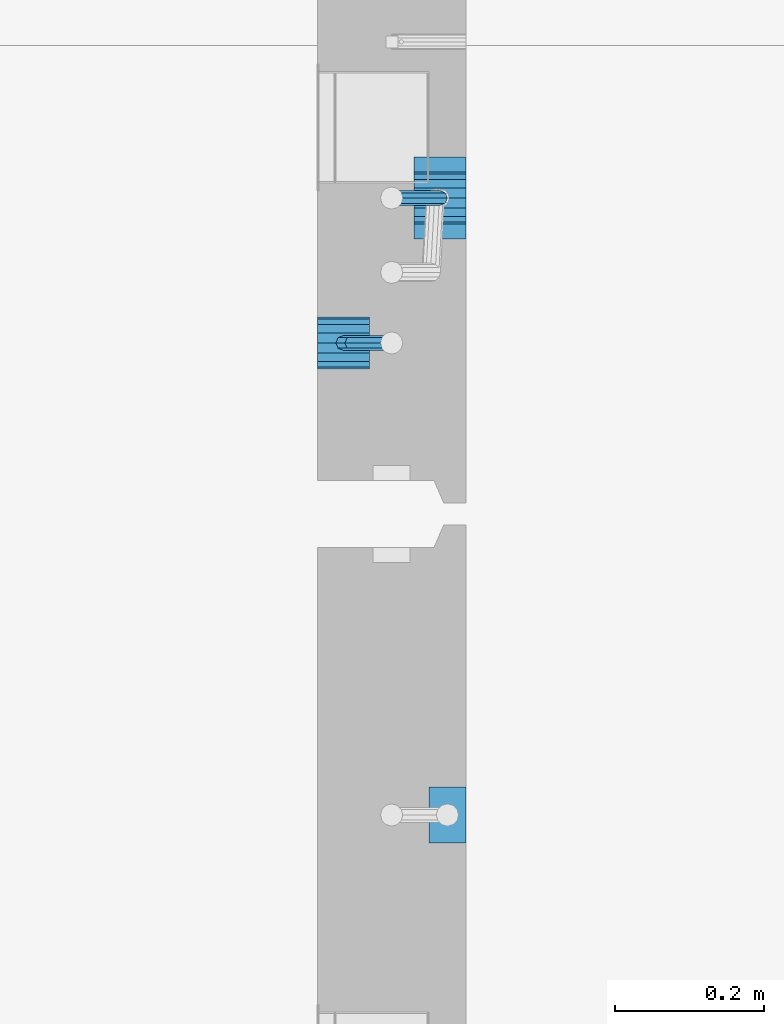
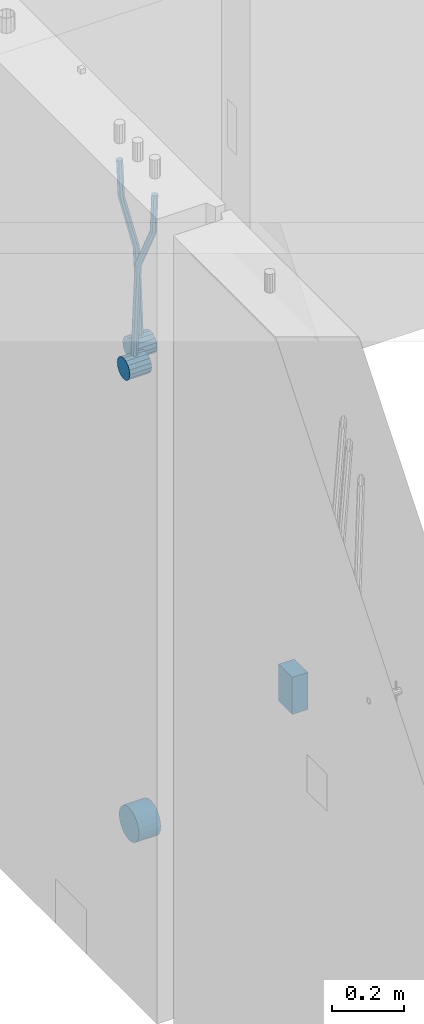
# One storey, part 141 of 334: 6 beams, 2 elements without a shape of their own.
"""IFC2X3 building model written with IfcOpenShell, lengths in millimetres."""

from ifc_helpers import new_model, si_unit, frame, origin_with_axes, place, context, subcontext, project, spatial, faceted_brep, material, type_object, element, aggregate, save


model = new_model("IFC2X3")

# Units and contexts
model_context = context("Model", 3, precision=1e-05, world=origin_with_axes())
body_context = subcontext(model_context, "Body", "Model", "MODEL_VIEW")
ifc_project = project(units=[si_unit("LENGTHUNIT", "METRE", prefix="MILLI"), si_unit("AREAUNIT", "SQUARE_METRE"), si_unit("VOLUMEUNIT", "CUBIC_METRE"), si_unit("MASSUNIT", "GRAM", prefix="KILO"), si_unit("TIMEUNIT", "SECOND"), si_unit("PLANEANGLEUNIT", "RADIAN"), si_unit("SOLIDANGLEUNIT", "STERADIAN"), si_unit("THERMODYNAMICTEMPERATUREUNIT", "DEGREE_CELSIUS"), si_unit("LUMINOUSINTENSITYUNIT", "LUMEN")], contexts=[model_context])

# Site, building, storey
site_placement = place(None, origin_with_axes())
site = spatial("IfcSite", under=ifc_project, at=site_placement, CompositionType="ELEMENT")
building_placement = place(site_placement, origin_with_axes())
building = spatial("IfcBuilding", under=site, at=building_placement, CompositionType="ELEMENT")
storey_placement = place(building_placement, origin_with_axes())
storey = spatial("IfcBuildingStorey", under=building, at=storey_placement, Name="3", CompositionType="ELEMENT", Elevation=0.0)

# Assembly, beams
assembly_1_placement = place(storey_placement, origin_with_axes())
assembly_1 = element("IfcElementAssembly", 1, at=assembly_1_placement, inside=storey, AssemblyPlace="NOTDEFINED", PredefinedType="REINFORCEMENT_UNIT")
ifc_material = material()
beam_type_1 = type_object("IfcBeamType", Name="D20", PredefinedType="NOTDEFINED")
beam_1_placement = place(assembly_1_placement, frame((21875.0000022791, 12925.0000000039, 89795.0), z_axis=(-0.999642804636942, -0.000205726999925762, -0.0267249099902983), x_axis=(-0.0267249099948371, 4.30000201934385e-08, 0.999642825806181)))
beam_1 = element("IfcBeam", 2, at=beam_1_placement, type_object=beam_type_1, material=ifc_material, Name="JM20", ObjectType="D20", context=body_context, shape_type="Brep", body=[
    faceted_brep([(0.0, -10.0, 0.0), (-4.19531716033816e-08, -7.07106781186667, -7.07106781187031), (60.4266690400545, -7.0710677960451, -7.07106780570757), (60.4266690441291, -9.99999998418934, 6.15546014159918e-09), (0.0, 0.0, -10.0), (60.426669036824, 1.58106558956206e-08, -9.99999999384454), (4.196772351861e-08, 7.07106781186303, -7.07106781186667), (60.4266690363438, 7.07106782768096, -7.07106780570757), (0.0, 10.0, 0.0), (60.4266690388904, 10.0000000158179, 6.15182216279209e-09), (4.196772351861e-08, 7.07106781185939, 7.07106781185939), (60.4266690429649, 7.07106782768096, 7.07106781802577), (0.0, 0.0, 10.0), (60.4266690461809, 1.58179318532348e-08, 10.0000000061555), (-4.19531716033816e-08, -7.07106781187031, 7.07106781185939), (60.4266690466611, -7.07106779605238, 7.07106781802213), (61.0378400410118, -7.07106779588503, -7.07106780564936), (60.991799419251, -9.99999998403655, 6.21366780251265e-09), (61.0569027789461, 1.5985278878361e-08, -9.99999999378269), (61.0378209396877, 7.07106782784831, -7.07106780564936), (60.9917724058905, 10.0000000159635, 6.21366780251265e-09), (60.9457317841297, 7.07106782781193, 7.0710678180767), (60.9266690461809, 1.59488990902901e-08, 10.0000000062028), (60.9457508854539, -7.07106779591413, 7.0710678180767), (61.6489592143771, -7.07106614513759, -7.06310863441468), (61.5568818710308, -9.9999984576425, 0.00735959856683621), (61.6870830769039, 1.71821739058942e-06, -9.99179257185824), (61.6489210170112, 7.07106947854481, -7.06310888312146), (61.556827851804, 10.0000015422847, 0.00735924683976918), (61.4647505084577, 7.07106922979438, 7.07782747982128), (61.4266266459163, 1.36643211590126e-06, 10.0065114172685), (61.464788705809, -7.07106639389531, 7.07782772852806), (176.543135720174, -7.07075579406956, -5.56673531796696), (176.451058376813, -9.99968810657447, 1.50373291501455), (176.581259582701, 0.000312069292704109, -8.49541925541052), (176.543097522794, 7.07137982961285, -5.56673556667374), (176.451004357587, 10.00031189336, 1.50373256329476), (176.35892701424, 7.07137958085514, 8.57420079627263), (176.320803151699, 0.000311717507429421, 11.5028847337162), (176.358965211621, -7.07075604281999, 8.57420104497578), (177.098753836006, -7.07075429323595, -5.55949898843028), (176.98362511232, -9.99968666800123, 1.510669025065), (177.146421932586, 0.000313595905026887, -8.48805862247536), (177.098706077581, 7.07138133041735, -5.55949936166144), (176.983557571715, 10.0003133318824, 1.51066849724157), (176.868428848029, 7.07138095712435, 8.58083651073321), (176.820760751449, 0.000313067976094317, 11.5093961447819), (176.868476606425, -7.07075466652896, 8.58083688396073), (177.654312950661, -7.07075204110879, -5.54863964998367), (177.516135294456, -9.99968450931192, 1.52107783331303), (177.711524267797, 0.000315886711177882, -8.47701274570863), (177.654255632195, 7.07138358250813, -5.54864021007961), (177.516054233929, 10.0003154905207, 1.5210770412159), (177.377876577739, 7.0713830223176, 8.59079452451624), (177.320665260588, 0.000315094497636892, 11.5191676202448), (177.377933896176, -7.07075260129932, 8.59079508461218), (298.592214475648, -7.07025824167067, -3.18470470795364), (298.454036904819, -9.99919071054683, 3.88501277673276), (298.649425586758, 0.000809686429420253, -6.11307780703646), (298.592156745173, 7.07187738194261, -3.18470527475802), (298.453955261604, 10.0008092892858, 3.88501197515143), (298.315777690761, 7.07187682041331, 10.9547294598378), (298.258566579665, 0.000808892309578368, 13.883102558917), (298.31583542125, -7.07025880319998, 10.9547300266422), (300.829882012156, -7.07024910539985, -3.14096572775816), (299.972022738802, -9.99918451269514, 3.91468436611831), (301.18507173346, 0.000820039333120803, -6.0635143331092), (300.829526581147, 7.07188651699835, -3.14097211362241), (299.971520083447, 10.0008154854204, 3.91467533514515), (299.113660810108, 7.07188007812692, 10.9703254290253), (298.758471088819, 0.000810933392131119, 13.8928740343799), (299.114016241103, -7.07025554427128, 10.9703318148859), (303.012825988379, -7.0701468967527, -2.64717965084128), (301.452885279024, -9.99911517653163, 4.24965828764471), (303.65870706641, 0.000935858577577164, -5.50397331873319), (303.012180137302, 7.07198871204673, -2.64725173027909), (301.451971907663, 10.0008848023517, 4.24955635192964), (299.892031198324, 7.07191652257279, 11.1463942904193), (299.246150120278, 0.000833767242511385, 14.0031879583075), (299.892677049385, -7.07021908622846, 11.1464663698534), (490.480206458145, -7.06136939830685, 39.7582981627347), (488.920265748791, -9.9903376780876, 46.6551361012243), (491.126087536177, 0.00971335702342913, 36.9015044948464), (490.479560607055, 7.0807662104944, 39.7582260832969), (488.91935237743, 10.0096623007976, 46.6550341655056), (487.359411668076, 7.08069402101864, 53.5518721039953), (486.713530590045, 0.00961126568654436, 56.4086657718872), (487.360057519167, -7.06144158778261, 53.5519441834331), (491.222094319732, -7.06133466202664, 39.9261146072568), (490.367102775039, -9.9902699350514, 46.9824133868096), (491.613766567636, 0.0097361908719904, 37.0118184187741), (491.312683227967, 7.08080521851844, 39.9466800038063), (490.495214837676, 10.0097360849959, 47.0114972495248), (489.640223292983, 7.08080081197113, 54.0677960290814), (489.248551045079, 0.00972995907250152, 56.9820922175604), (489.549634384748, -7.06133906857212, 54.0472306325282), (491.98259360576, -7.07125184727738, 39.9362361015701), (491.850235984879, -10.009610527557, 47.0021524248696), (492.113679795017, 0.00321714190249622, 37.0184717700395), (492.166706040836, 7.06966845271199, 39.958046203883), (492.110610287549, 9.988670745126, 47.0329965673554), (491.978252666668, 7.05031206484455, 54.0989128906476), (491.847166477397, -0.0241569243353297, 57.0166772221819), (491.794140231592, -7.09060823514483, 54.077102788342), (512.839684553823, -7.34323584322192, 40.2138233804726), (512.707326932941, -10.2815945235034, 47.2797397037684), (512.970770743079, -0.268766854042042, 37.296059048942), (513.023796988884, 6.79768445676746, 40.2356334827819), (512.967701235597, 9.71668674918146, 47.3105838462543), (512.83534361473, 6.77832806890183, 54.3765001695538), (512.704257425459, -0.296140920279868, 57.2942645010808), (512.651231179654, -7.36259223108937, 54.3546900672372), (513.475042066755, -7.35152113457298, 40.2222793613946), (513.367413171509, -10.2902022863618, 47.2885247996019), (513.548971693657, -0.276306803183616, 37.3037543324754), (513.545895079456, 6.79087610917486, 40.2425820926655), (513.467614462992, 9.71016770021379, 47.3172371975234), (513.359985567746, 6.77148654842495, 54.3834826357306), (513.286055940844, -0.303727782968053, 57.3020076646499), (513.289132555044, -7.37091069532653, 54.3631799044524), (514.110453382629, -7.34964673829199, 40.2305416874733), (514.027555144421, -10.2882337755309, 47.2971163788461), (514.127221878356, -0.274611275939606, 37.3112548247955), (514.06803787424, 6.7924127919523, 40.249334442502), (513.967570557215, 9.71165861202826, 47.3236933478729), (513.884672319007, 6.77307157479117, 54.3902680392421), (513.867903823266, -0.301963887563034, 57.3095549019235), (513.927087827382, -7.36898795545494, 54.3714752842207), (614.131240716772, -7.05138387012084, 41.5279197320488), (614.048342478563, -9.98997090735793, 48.5944944234179), (614.148009212484, 0.0236515922315448, 38.6086328693636), (614.088825208368, 7.09067566012527, 41.5467124870702), (613.988357891343, 10.0099214802012, 48.6210713924484), (613.905459653135, 7.07133444296232, 55.6876460838175), (613.888691157408, -0.00370101939006418, 58.606932946499), (613.947875161524, -7.07072508728379, 55.6688533287888)], [[[0, 1, 2, 3]], [[1, 4, 5, 2]], [[4, 6, 7, 5]], [[6, 8, 9, 7]], [[8, 10, 11, 9]], [[10, 12, 13, 11]], [[12, 14, 15, 13]], [[14, 0, 3, 15]], [[14, 12, 10, 8, 6, 4, 1, 0]], [[3, 2, 16, 17]], [[2, 5, 18, 16]], [[5, 7, 19, 18]], [[7, 9, 20, 19]], [[9, 11, 21, 20]], [[11, 13, 22, 21]], [[13, 15, 23, 22]], [[15, 3, 17, 23]], [[17, 16, 24, 25]], [[16, 18, 26, 24]], [[18, 19, 27, 26]], [[19, 20, 28, 27]], [[20, 21, 29, 28]], [[21, 22, 30, 29]], [[22, 23, 31, 30]], [[23, 17, 25, 31]], [[25, 24, 32, 33]], [[24, 26, 34, 32]], [[26, 27, 35, 34]], [[27, 28, 36, 35]], [[28, 29, 37, 36]], [[29, 30, 38, 37]], [[30, 31, 39, 38]], [[31, 25, 33, 39]], [[33, 32, 40, 41]], [[32, 34, 42, 40]], [[34, 35, 43, 42]], [[35, 36, 44, 43]], [[36, 37, 45, 44]], [[37, 38, 46, 45]], [[38, 39, 47, 46]], [[39, 33, 41, 47]], [[41, 40, 48, 49]], [[40, 42, 50, 48]], [[42, 43, 51, 50]], [[43, 44, 52, 51]], [[44, 45, 53, 52]], [[45, 46, 54, 53]], [[46, 47, 55, 54]], [[47, 41, 49, 55]], [[49, 48, 56, 57]], [[48, 50, 58, 56]], [[50, 51, 59, 58]], [[51, 52, 60, 59]], [[52, 53, 61, 60]], [[53, 54, 62, 61]], [[54, 55, 63, 62]], [[55, 49, 57, 63]], [[57, 56, 64, 65]], [[56, 58, 66, 64]], [[58, 59, 67, 66]], [[59, 60, 68, 67]], [[60, 61, 69, 68]], [[61, 62, 70, 69]], [[62, 63, 71, 70]], [[63, 57, 65, 71]], [[65, 64, 72, 73]], [[64, 66, 74, 72]], [[66, 67, 75, 74]], [[67, 68, 76, 75]], [[68, 69, 77, 76]], [[69, 70, 78, 77]], [[70, 71, 79, 78]], [[71, 65, 73, 79]], [[73, 72, 80, 81]], [[72, 74, 82, 80]], [[74, 75, 83, 82]], [[75, 76, 84, 83]], [[76, 77, 85, 84]], [[77, 78, 86, 85]], [[78, 79, 87, 86]], [[79, 73, 81, 87]], [[81, 80, 88, 89]], [[80, 82, 90, 88]], [[82, 83, 91, 90]], [[83, 84, 92, 91]], [[84, 85, 93, 92]], [[85, 86, 94, 93]], [[86, 87, 95, 94]], [[87, 81, 89, 95]], [[89, 88, 96, 97]], [[88, 90, 98, 96]], [[90, 91, 99, 98]], [[91, 92, 100, 99]], [[92, 93, 101, 100]], [[93, 94, 102, 101]], [[94, 95, 103, 102]], [[95, 89, 97, 103]], [[97, 96, 104, 105]], [[96, 98, 106, 104]], [[98, 99, 107, 106]], [[99, 100, 108, 107]], [[100, 101, 109, 108]], [[101, 102, 110, 109]], [[102, 103, 111, 110]], [[103, 97, 105, 111]], [[105, 104, 112, 113]], [[104, 106, 114, 112]], [[106, 107, 115, 114]], [[107, 108, 116, 115]], [[108, 109, 117, 116]], [[109, 110, 118, 117]], [[110, 111, 119, 118]], [[111, 105, 113, 119]], [[113, 112, 120, 121]], [[112, 114, 122, 120]], [[114, 115, 123, 122]], [[115, 116, 124, 123]], [[116, 117, 125, 124]], [[117, 118, 126, 125]], [[118, 119, 127, 126]], [[119, 113, 121, 127]], [[121, 120, 128, 129]], [[120, 122, 130, 128]], [[122, 123, 131, 130]], [[123, 124, 132, 131]], [[124, 125, 133, 132]], [[125, 126, 134, 133]], [[126, 127, 135, 134]], [[127, 121, 129, 135]], [[130, 131, 132, 133, 134, 135, 129, 128]]]),
])
beam_2_placement = place(assembly_1_placement, frame((21744.9999977209, 12729.9999999961, 89890.0), z_axis=(0.999642804629538, 0.000205762999925497, -0.0267249099901003), x_axis=(0.0267249109941254, -4.30000210532798e-08, 0.999642825779465)))
beam_2 = element("IfcBeam", 3, at=beam_2_placement, type_object=beam_type_1, material=ifc_material, Name="JM20", ObjectType="D20", context=body_context, shape_type="Brep", body=[
    faceted_brep([(0.0, -10.0, 0.0), (-4.19531716033816e-08, -7.07106781186667, -7.07106781187031), (60.4266690400545, -7.0710677960451, -7.07106780570757), (60.4266690441291, -9.99999998418934, 6.15546014159918e-09), (0.0, 0.0, -10.0), (60.426669036824, 1.58106558956206e-08, -9.99999999384454), (4.196772351861e-08, 7.07106781186303, -7.07106781186667), (60.4266690363438, 7.07106782768096, -7.07106780570757), (0.0, 10.0, 0.0), (60.4266690388904, 10.0000000158179, 6.15182216279209e-09), (4.196772351861e-08, 7.07106781185939, 7.07106781185939), (60.4266690429649, 7.07106782768096, 7.07106781802577), (0.0, 0.0, 10.0), (60.4266690461809, 1.58179318532348e-08, 10.0000000061555), (-4.19531716033816e-08, -7.07106781187031, 7.07106781185939), (60.4266690466611, -7.07106779605238, 7.07106781802213), (61.0378400410118, -7.07106779588503, -7.07106780564936), (60.991799419251, -9.99999998403655, 6.21366780251265e-09), (61.0569027789461, 1.5985278878361e-08, -9.99999999378269), (61.0378209396877, 7.07106782784831, -7.07106780564936), (60.9917724058905, 10.0000000159635, 6.21366780251265e-09), (60.9457317841297, 7.07106782781193, 7.0710678180767), (60.9266690461809, 1.59488990902901e-08, 10.0000000062028), (60.9457508854539, -7.07106779591413, 7.0710678180767), (61.6489592143771, -7.07106614513759, -7.06310863441468), (61.5568818710308, -9.9999984576425, 0.00735959856683621), (61.6870830769039, 1.71821739058942e-06, -9.99179257185824), (61.6489210170112, 7.07106947854481, -7.06310888312146), (61.556827851804, 10.0000015422847, 0.00735924683976918), (61.4647505084577, 7.07106922979438, 7.07782747982128), (61.4266266459163, 1.36643211590126e-06, 10.0065114172685), (61.464788705809, -7.07106639389531, 7.07782772852806), (176.543135720174, -7.07075579406956, -5.56673531796696), (176.451058376813, -9.99968810657447, 1.50373291501455), (176.581259582701, 0.000312069292704109, -8.49541925541052), (176.543097522794, 7.07137982961285, -5.56673556667374), (176.451004357587, 10.00031189336, 1.50373256329476), (176.35892701424, 7.07137958085514, 8.57420079627263), (176.320803151699, 0.000311717507429421, 11.5028847337162), (176.358965211621, -7.07075604281999, 8.57420104497578), (177.098753836006, -7.07075429323595, -5.55949898843028), (176.98362511232, -9.99968666800123, 1.510669025065), (177.146421932586, 0.000313595905026887, -8.48805862247536), (177.098706077581, 7.07138133041735, -5.55949936166144), (176.983557571715, 10.0003133318824, 1.51066849724157), (176.868428848029, 7.07138095712435, 8.58083651073321), (176.820760751449, 0.000313067976094317, 11.5093961447819), (176.868476606425, -7.07075466652896, 8.58083688396073), (177.654312950661, -7.07075204110879, -5.54863964998367), (177.516135294456, -9.99968450931192, 1.52107783331303), (177.711524267797, 0.000315886711177882, -8.47701274570863), (177.654255632195, 7.07138358250813, -5.54864021007961), (177.516054233929, 10.0003154905207, 1.5210770412159), (177.377876577739, 7.0713830223176, 8.59079452451624), (177.320665260588, 0.000315094497636892, 11.5191676202448), (177.377933896176, -7.07075260129932, 8.59079508461218), (297.446964549832, -7.07026642590426, -3.20709054437975), (297.308786893627, -9.99919889410376, 3.86262693891331), (297.504175866998, 0.000801501919340808, -6.13546364010836), (297.44690723141, 7.07186919770902, -3.20709110447569), (297.308705833115, 10.0008011057289, 3.86262614682164), (297.170528176895, 7.07186863752577, 10.9323436301165), (297.113316859759, 0.000800709702161839, 13.8607167258415), (297.170585495318, -7.07026698608752, 10.9323441902106), (301.63986343499, -7.07024942873613, -3.12513327486886), (299.972259732356, -9.99918809692099, 3.91468900081236), (302.330321453323, 0.000821066147182137, -6.04112849743797), (301.639172844472, 7.07188619231601, -3.12514621333321), (299.971283089879, 10.0008118992846, 3.91467070306135), (298.303679387245, 7.07187323109611, 10.9544929787371), (297.613221368898, 0.000802736216428457, 13.870488201308), (298.304369977734, -7.0702623899524, 10.9545059172033), (305.4239078393, -7.06987516590743, -1.31733741553398), (302.376014215231, -9.99895035236841, 5.06306278734701), (306.685863931343, 0.00125185327851796, -3.96030416885333), (305.422645727784, 7.07226039861052, -1.31762339341367), (302.374229320019, 10.0010495638962, 5.06265835355225), (299.326335695951, 7.07197437743162, 11.4430585564332), (298.064379603893, 0.000847358245664509, 14.0860253097508), (299.327597807453, -7.07016118708634, 11.4433445343111), (396.081143409523, -7.0609086662007, 41.9934056867296), (393.033249785469, -9.98998385266168, 48.3738058896106), (397.34309950161, 0.0102183529888862, 39.3504389334103), (396.079881298036, 7.08122689832453, 41.9931197088481), (393.031464890271, 10.0100160636066, 48.3734014558122), (389.983571266188, 7.08094087714562, 54.753801658695), (388.72161517413, 0.00981385795967071, 57.3967684120162), (389.984833377704, -7.06119468737961, 54.7540876365765), (397.068790959223, -7.06081098241702, 42.4652461198857), (395.403898118791, -9.98974938248648, 49.5063634875187), (397.79425773659, 0.0102629750217602, 39.565976041853), (397.155329851754, 7.08133326610914, 42.5069063441551), (395.526282594277, 10.0102628148125, 49.5652799416912), (393.861389753831, 7.08132441474299, 56.606397309326), (393.135922976478, 0.0102504573078477, 59.5056673873569), (393.774850861315, -7.06081983378317, 56.5647370850584), (398.163169908337, -7.0750819080713, 42.4798112226927), (398.030733605352, -10.0240038552729, 49.541324073105), (398.294170965004, 0.00374400413056719, 39.572629393122), (398.346998133013, 7.06579366763617, 42.5227662718698), (398.290705973835, 9.97421416771613, 49.6020716862276), (398.15826967085, 7.02529222051089, 56.6635845366436), (398.027268614198, -0.0535336916836968, 59.5707663662142), (397.974441446175, -7.11558335519294, 56.6206294874646), (417.87389934808, -7.33211385723553, 42.7421415616409), (417.741463045095, -10.2810358044335, 49.803654412055), (418.004900404732, -0.253287945030024, 39.8349597320685), (418.057727572756, 6.8087617184683, 42.7850966108181), (418.001435413564, 9.71718221855917, 49.8644020251777), (417.868999110593, 6.76826027135394, 56.92591487559), (417.737998053926, -0.310565640847926, 59.8330967051625), (417.685170885918, -7.37261530435353, 56.8829598264128), (418.509166047603, -7.3403978651113, 42.7505963339045), (418.401542092906, -10.2896433704191, 49.812439412166), (418.582978010687, -0.260826195415575, 39.8426533739894), (418.579739935274, 6.80195457034279, 42.7920440797316), (418.501348641992, 9.71066324766434, 49.8710553764413), (418.393724687281, 6.76141774235657, 56.9328984547028), (418.319912724211, -0.318153927339154, 59.8408414146197), (418.323150799639, -7.38093469310479, 56.8914507088775), (419.144486528079, -7.33852513420788, 42.7588588031304), (419.061676848418, -10.2876749343814, 49.821032815089), (419.161104845465, -0.25913295731516, 39.8501522177412), (419.101797015624, 6.80348967242753, 42.7987939276718), (419.00130476091, 9.71215420445515, 49.8775096098252), (418.918495081249, 6.76300440428531, 56.9396836217802), (418.901876763863, -0.316387772607413, 59.8483902071712), (418.961184593718, -7.37901040236102, 56.8997484972406), (519.165277458538, -7.04026297675227, 44.0562368946885), (519.082467778877, -9.98941277692575, 51.1184109066417), (519.181895775939, 0.0391292001404508, 41.1475303092957), (519.122587946098, 7.10175182989406, 44.0961720192245), (519.022095691384, 10.0104163619108, 51.1748877013797), (518.939286011722, 7.06126656174456, 58.2370617133347), (518.922667694336, -0.0181256151481648, 61.1457682987275), (518.981975524162, -7.08074824490541, 58.1971265887951)], [[[0, 1, 2, 3]], [[1, 4, 5, 2]], [[4, 6, 7, 5]], [[6, 8, 9, 7]], [[8, 10, 11, 9]], [[10, 12, 13, 11]], [[12, 14, 15, 13]], [[14, 0, 3, 15]], [[14, 12, 10, 8, 6, 4, 1, 0]], [[3, 2, 16, 17]], [[2, 5, 18, 16]], [[5, 7, 19, 18]], [[7, 9, 20, 19]], [[9, 11, 21, 20]], [[11, 13, 22, 21]], [[13, 15, 23, 22]], [[15, 3, 17, 23]], [[17, 16, 24, 25]], [[16, 18, 26, 24]], [[18, 19, 27, 26]], [[19, 20, 28, 27]], [[20, 21, 29, 28]], [[21, 22, 30, 29]], [[22, 23, 31, 30]], [[23, 17, 25, 31]], [[25, 24, 32, 33]], [[24, 26, 34, 32]], [[26, 27, 35, 34]], [[27, 28, 36, 35]], [[28, 29, 37, 36]], [[29, 30, 38, 37]], [[30, 31, 39, 38]], [[31, 25, 33, 39]], [[33, 32, 40, 41]], [[32, 34, 42, 40]], [[34, 35, 43, 42]], [[35, 36, 44, 43]], [[36, 37, 45, 44]], [[37, 38, 46, 45]], [[38, 39, 47, 46]], [[39, 33, 41, 47]], [[41, 40, 48, 49]], [[40, 42, 50, 48]], [[42, 43, 51, 50]], [[43, 44, 52, 51]], [[44, 45, 53, 52]], [[45, 46, 54, 53]], [[46, 47, 55, 54]], [[47, 41, 49, 55]], [[49, 48, 56, 57]], [[48, 50, 58, 56]], [[50, 51, 59, 58]], [[51, 52, 60, 59]], [[52, 53, 61, 60]], [[53, 54, 62, 61]], [[54, 55, 63, 62]], [[55, 49, 57, 63]], [[57, 56, 64, 65]], [[56, 58, 66, 64]], [[58, 59, 67, 66]], [[59, 60, 68, 67]], [[60, 61, 69, 68]], [[61, 62, 70, 69]], [[62, 63, 71, 70]], [[63, 57, 65, 71]], [[65, 64, 72, 73]], [[64, 66, 74, 72]], [[66, 67, 75, 74]], [[67, 68, 76, 75]], [[68, 69, 77, 76]], [[69, 70, 78, 77]], [[70, 71, 79, 78]], [[71, 65, 73, 79]], [[73, 72, 80, 81]], [[72, 74, 82, 80]], [[74, 75, 83, 82]], [[75, 76, 84, 83]], [[76, 77, 85, 84]], [[77, 78, 86, 85]], [[78, 79, 87, 86]], [[79, 73, 81, 87]], [[81, 80, 88, 89]], [[80, 82, 90, 88]], [[82, 83, 91, 90]], [[83, 84, 92, 91]], [[84, 85, 93, 92]], [[85, 86, 94, 93]], [[86, 87, 95, 94]], [[87, 81, 89, 95]], [[89, 88, 96, 97]], [[88, 90, 98, 96]], [[90, 91, 99, 98]], [[91, 92, 100, 99]], [[92, 93, 101, 100]], [[93, 94, 102, 101]], [[94, 95, 103, 102]], [[95, 89, 97, 103]], [[97, 96, 104, 105]], [[96, 98, 106, 104]], [[98, 99, 107, 106]], [[99, 100, 108, 107]], [[100, 101, 109, 108]], [[101, 102, 110, 109]], [[102, 103, 111, 110]], [[103, 97, 105, 111]], [[105, 104, 112, 113]], [[104, 106, 114, 112]], [[106, 107, 115, 114]], [[107, 108, 116, 115]], [[108, 109, 117, 116]], [[109, 110, 118, 117]], [[110, 111, 119, 118]], [[111, 105, 113, 119]], [[113, 112, 120, 121]], [[112, 114, 122, 120]], [[114, 115, 123, 122]], [[115, 116, 124, 123]], [[116, 117, 125, 124]], [[117, 118, 126, 125]], [[118, 119, 127, 126]], [[119, 113, 121, 127]], [[121, 120, 128, 129]], [[120, 122, 130, 128]], [[122, 123, 131, 130]], [[123, 124, 132, 131]], [[124, 125, 133, 132]], [[125, 126, 134, 133]], [[126, 127, 135, 134]], [[127, 121, 129, 135]], [[130, 131, 132, 133, 134, 135, 129, 128]]]),
])
beam_type_2 = type_object("IfcBeamType", Name="D70", PredefinedType="NOTDEFINED")
beam_3_placement = place(assembly_1_placement, frame((21839.9999977209, 12925.0, 89760.0), z_axis=(0.0, 0.0, 1.0), x_axis=(1.0, 0.0, 0.0)))
beam_3 = element("IfcBeam", 4, at=beam_3_placement, type_object=beam_type_2, material=ifc_material, ObjectType="D70", context=body_context, shape_type="Brep", body=[
    faceted_brep([(0.0, -35.0, 0.0), (0.0, -32.3357836378964, -13.3939201327739), (70.0, -32.3357836378964, -13.3939201327739), (70.0, -35.0, 0.0), (0.0, -24.7487373415279, -24.7487373415352), (70.0, -24.7487373415279, -24.7487373415352), (0.0, -13.3939201327776, -32.3357836379), (70.0, -13.3939201327776, -32.3357836379), (0.0, 0.0, -35.0), (70.0, 0.0, -35.0), (0.0, 13.3939201327776, -32.3357836379), (70.0, 13.3939201327776, -32.3357836379), (0.0, 24.7487373415279, -24.7487373415352), (70.0, 24.7487373415279, -24.7487373415352), (0.0, 32.3357836378964, -13.3939201327739), (70.0, 32.3357836378964, -13.3939201327739), (0.0, 35.0, 0.0), (70.0, 35.0, 0.0), (0.0, 32.3357836378964, 13.3939201327739), (70.0, 32.3357836378964, 13.3939201327739), (0.0, 24.7487373415279, 24.7487373415352), (70.0, 24.7487373415279, 24.7487373415352), (0.0, 13.3939201327776, 32.3357836379), (70.0, 13.3939201327776, 32.3357836379), (0.0, 0.0, 35.0), (70.0, 0.0, 35.0), (0.0, -13.3939201327776, 32.3357836379), (70.0, -13.3939201327776, 32.3357836379), (0.0, -24.7487373415279, 24.7487373415352), (70.0, -24.7487373415279, 24.7487373415352), (0.0, -32.3357836378964, 13.3939201327739), (70.0, -32.3357836378964, 13.3939201327739)], [[[0, 1, 2, 3]], [[1, 4, 5, 2]], [[4, 6, 7, 5]], [[6, 8, 9, 7]], [[8, 10, 11, 9]], [[10, 12, 13, 11]], [[12, 14, 15, 13]], [[14, 16, 17, 15]], [[16, 18, 19, 17]], [[18, 20, 21, 19]], [[20, 22, 23, 21]], [[22, 24, 25, 23]], [[24, 26, 27, 25]], [[26, 28, 29, 27]], [[28, 30, 31, 29]], [[30, 0, 3, 31]], [[5, 7, 9, 11, 13, 15, 17, 19, 21, 23, 25, 27, 29, 31, 3, 2]], [[30, 28, 26, 24, 22, 20, 18, 16, 14, 12, 10, 8, 6, 4, 1, 0]]]),
])
beam_4_placement = place(assembly_1_placement, frame((21709.9999977209, 12730.0, 89855.0), z_axis=(0.0, 0.0, 1.0), x_axis=(1.0, 0.0, 0.0)))
beam_4 = element("IfcBeam", 5, at=beam_4_placement, type_object=beam_type_2, material=ifc_material, ObjectType="D70", context=body_context, shape_type="Brep", body=[
    faceted_brep([(0.0, -35.0, 0.0), (0.0, -32.3357836378964, -13.3939201327739), (70.0, -32.3357836378964, -13.3939201327739), (70.0, -35.0, 0.0), (0.0, -24.7487373415279, -24.7487373415352), (70.0, -24.7487373415279, -24.7487373415352), (0.0, -13.3939201327776, -32.3357836379), (70.0, -13.3939201327776, -32.3357836379), (0.0, 0.0, -35.0), (70.0, 0.0, -35.0), (0.0, 13.3939201327776, -32.3357836379), (70.0, 13.3939201327776, -32.3357836379), (0.0, 24.7487373415279, -24.7487373415352), (70.0, 24.7487373415279, -24.7487373415352), (0.0, 32.3357836378964, -13.3939201327739), (70.0, 32.3357836378964, -13.3939201327739), (0.0, 35.0, 0.0), (70.0, 35.0, 0.0), (0.0, 32.3357836378964, 13.3939201327739), (70.0, 32.3357836378964, 13.3939201327739), (0.0, 24.7487373415279, 24.7487373415352), (70.0, 24.7487373415279, 24.7487373415352), (0.0, 13.3939201327776, 32.3357836379), (70.0, 13.3939201327776, 32.3357836379), (0.0, 0.0, 35.0), (70.0, 0.0, 35.0), (0.0, -13.3939201327776, 32.3357836379), (70.0, -13.3939201327776, 32.3357836379), (0.0, -24.7487373415279, 24.7487373415352), (70.0, -24.7487373415279, 24.7487373415352), (0.0, -32.3357836378964, 13.3939201327739), (70.0, -32.3357836378964, 13.3939201327739)], [[[0, 1, 2, 3]], [[1, 4, 5, 2]], [[4, 6, 7, 5]], [[6, 8, 9, 7]], [[8, 10, 11, 9]], [[10, 12, 13, 11]], [[12, 14, 15, 13]], [[14, 16, 17, 15]], [[16, 18, 19, 17]], [[18, 20, 21, 19]], [[20, 22, 23, 21]], [[22, 24, 25, 23]], [[24, 26, 27, 25]], [[26, 28, 29, 27]], [[28, 30, 31, 29]], [[30, 0, 3, 31]], [[5, 7, 9, 11, 13, 15, 17, 19, 21, 23, 25, 27, 29, 31, 3, 2]], [[30, 28, 26, 24, 22, 20, 18, 16, 14, 12, 10, 8, 6, 4, 1, 0]]]),
])
beam_type_3 = type_object("IfcBeamType", Name="D110", PredefinedType="NOTDEFINED")
beam_5_placement = place(assembly_1_placement, frame((21910.0000022791, 12925.0, 88155.0), z_axis=(0.0, 0.0, 1.0), x_axis=(-1.0, 3.00000001838171e-08, 0.0)))
beam_5 = element("IfcBeam", 6, at=beam_5_placement, type_object=beam_type_3, material=ifc_material, ObjectType="D110", context=body_context, shape_type="Brep", body=[
    faceted_brep([(0.0, -55.0, 0.0), (0.0, -52.3081083962352, -16.9959346906253), (70.0, -52.3081083962352, -16.9959346906253), (70.0, -55.0, 0.0), (0.0, -44.4959346906217, -32.328188876083), (70.0, -44.4959346906217, -32.328188876083), (0.0, -32.3281888760866, -44.4959346906253), (70.0, -32.3281888760866, -44.4959346906253), (0.0, -16.9959346906217, -52.3081083962315), (70.0, -16.9959346906217, -52.3081083962315), (0.0, 0.0, -55.0), (70.0, 0.0, -55.0), (0.0, 16.9959346906217, -52.3081083962315), (70.0, 16.9959346906217, -52.3081083962315), (0.0, 32.3281888760866, -44.4959346906253), (70.0, 32.3281888760866, -44.4959346906253), (0.0, 44.4959346906217, -32.328188876083), (70.0, 44.4959346906217, -32.328188876083), (0.0, 52.3081083962352, -16.9959346906253), (70.0, 52.3081083962352, -16.9959346906253), (0.0, 55.0, 0.0), (70.0, 55.0, 0.0), (0.0, 52.3081083962352, 16.9959346906253), (70.0, 52.3081083962352, 16.9959346906253), (0.0, 44.4959346906217, 32.328188876083), (70.0, 44.4959346906217, 32.328188876083), (0.0, 32.3281888760866, 44.4959346906253), (70.0, 32.3281888760866, 44.4959346906253), (0.0, 16.9959346906217, 52.3081083962315), (70.0, 16.9959346906217, 52.3081083962315), (0.0, 0.0, 55.0), (70.0, 0.0, 55.0), (0.0, -16.9959346906217, 52.3081083962315), (70.0, -16.9959346906217, 52.3081083962315), (0.0, -32.3281888760866, 44.4959346906253), (70.0, -32.3281888760866, 44.4959346906253), (0.0, -44.4959346906217, 32.328188876083), (70.0, -44.4959346906217, 32.328188876083), (0.0, -52.3081083962352, 16.9959346906253), (70.0, -52.3081083962352, 16.9959346906253)], [[[0, 1, 2, 3]], [[1, 4, 5, 2]], [[4, 6, 7, 5]], [[6, 8, 9, 7]], [[8, 10, 11, 9]], [[10, 12, 13, 11]], [[12, 14, 15, 13]], [[14, 16, 17, 15]], [[16, 18, 19, 17]], [[18, 20, 21, 19]], [[20, 22, 23, 21]], [[22, 24, 25, 23]], [[24, 26, 27, 25]], [[26, 28, 29, 27]], [[28, 30, 31, 29]], [[30, 32, 33, 31]], [[32, 34, 35, 33]], [[34, 36, 37, 35]], [[36, 38, 39, 37]], [[38, 0, 3, 39]], [[5, 7, 9, 11, 13, 15, 17, 19, 21, 23, 25, 27, 29, 31, 33, 35, 37, 39, 3, 2]], [[38, 36, 34, 32, 30, 28, 26, 24, 22, 20, 18, 16, 14, 12, 10, 8, 6, 4, 1, 0]]]),
])
aggregate(assembly_1, [beam_1, beam_3, beam_2, beam_4, beam_5])

# Assembly, beam
assembly_2_placement = place(storey_placement, origin_with_axes())
assembly_2 = element("IfcElementAssembly", 7, at=assembly_2_placement, inside=storey, AssemblyPlace="NOTDEFINED", PredefinedType="REINFORCEMENT_UNIT")
beam_type_4 = type_object("IfcBeamType", Name="125X50", PredefinedType="NOTDEFINED")
beam_6_placement = place(assembly_2_placement, frame((21885.0, 12057.5, 89105.0), z_axis=(0.0, 0.0, 1.0), x_axis=(0.0, 1.0, 0.0)))
beam_6 = element("IfcBeam", 8, at=beam_6_placement, type_object=beam_type_4, material=ifc_material, Name="WM1", ObjectType="125X50", context=body_context, shape_type="Brep", body=[
    faceted_brep([(0.0, 25.0, -62.5), (0.0, 25.0, 62.5), (75.0, 25.0, 62.5), (75.0, 25.0, -62.5), (0.0, -25.0, 62.5), (75.0, -25.0, 62.5), (0.0, -25.0, -62.5), (75.0, -25.0, -62.5)], [[[0, 1, 2, 3]], [[1, 4, 5, 2]], [[4, 6, 7, 5]], [[6, 0, 3, 7]], [[5, 7, 3, 2]], [[0, 6, 4, 1]]]),
])
aggregate(assembly_2, [beam_6])

save(model, "model.ifc")
